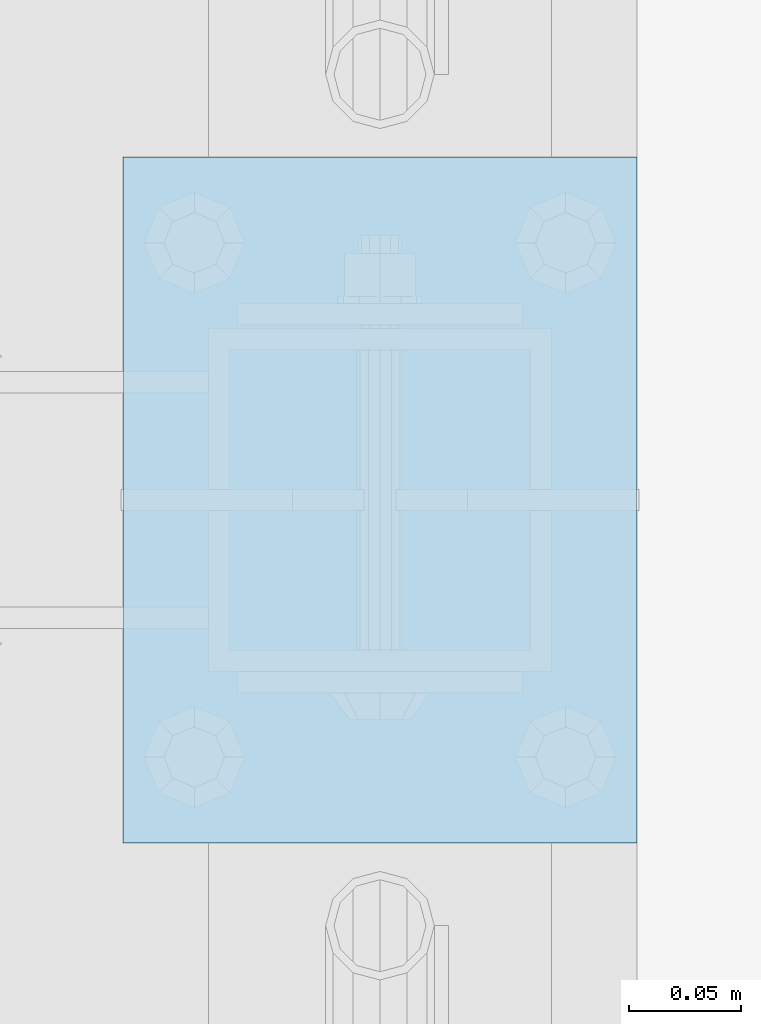
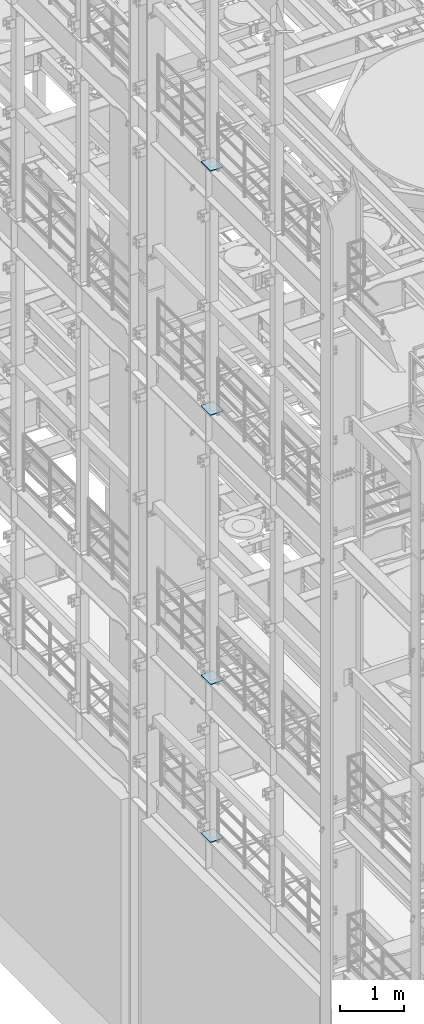
# One storey, part 1534 of 1876: 4 plates, 4 elements without a shape of their own.
"""IFC2X3 building model written with IfcOpenShell, lengths in millimetres."""

from ifc_helpers import new_model, si_unit, frame, origin_with_axes, place, context, subcontext, project, spatial, faceted_brep, material, type_object, element, aggregate, save


model = new_model("IFC2X3")

# Units and contexts
model_context = context("Model", 3, precision=1e-05, world=origin_with_axes())
body_context = subcontext(model_context, "Body", "Model", "MODEL_VIEW")
ifc_project = project(units=[si_unit("LENGTHUNIT", "METRE", prefix="MILLI"), si_unit("AREAUNIT", "SQUARE_METRE"), si_unit("VOLUMEUNIT", "CUBIC_METRE"), si_unit("MASSUNIT", "GRAM", prefix="KILO"), si_unit("TIMEUNIT", "SECOND"), si_unit("PLANEANGLEUNIT", "RADIAN"), si_unit("SOLIDANGLEUNIT", "STERADIAN"), si_unit("THERMODYNAMICTEMPERATUREUNIT", "DEGREE_CELSIUS"), si_unit("LUMINOUSINTENSITYUNIT", "LUMEN")], contexts=[model_context])

# Site, building, storey
site_placement = place(None, origin_with_axes())
site = spatial("IfcSite", under=ifc_project, at=site_placement, CompositionType="ELEMENT")
building_placement = place(site_placement, origin_with_axes())
building = spatial("IfcBuilding", under=site, at=building_placement, Name="Undefined", CompositionType="ELEMENT")
storey_placement = place(building_placement, origin_with_axes())
storey = spatial("IfcBuildingStorey", under=building, at=storey_placement, Name="Undefined", CompositionType="ELEMENT", Elevation=0.0)

# Assembly, plate
assembly_1_placement = place(storey_placement, origin_with_axes())
assembly_1 = element("IfcElementAssembly", 1, at=assembly_1_placement, inside=storey, Name="BEAM", AssemblyPlace="NOTDEFINED", PredefinedType="RIGID_FRAME")
ifc_material = material(Name="STEEL/A36")
plate_type = type_object("IfcPlateType", PredefinedType="NOTDEFINED")
plate_1_placement = place(assembly_1_placement, frame((-114.3, -660.400000000001, 17989.55), z_axis=(0.0, 1.0, 0.0), x_axis=(1.0, 0.0, 0.0)))
plate_1 = element("IfcPlate", 2, at=plate_1_placement, type_object=plate_type, material=ifc_material, Name="PLATE", context=body_context, shape_type="Brep", body=[
    faceted_brep([(0.0, -6.35000000000036, 0.0), (0.0, -6.35000000000036, 304.799987792969), (0.0, 6.35000000000036, 304.799987792969), (0.0, 6.35000000000036, 0.0), (228.600006103516, -6.34999999999854, 304.799987792969), (228.600006103516, 6.34999999999854, 304.799987792969), (228.600006103516, -6.34999999999854, 0.0), (228.600006103516, 6.34999999999854, 0.0)], [[[0, 1, 2, 3]], [[1, 4, 5, 2]], [[4, 6, 7, 5]], [[6, 0, 3, 7]], [[5, 7, 3, 2]], [[6, 4, 1, 0]]]),
])
aggregate(assembly_1, [plate_1])

assembly_2_placement = place(storey_placement, origin_with_axes())
assembly_2 = element("IfcElementAssembly", 3, at=assembly_2_placement, inside=storey, Name="BEAM", AssemblyPlace="NOTDEFINED", PredefinedType="RIGID_FRAME")
plate_2_placement = place(assembly_2_placement, frame((-114.3, -660.400000000001, 13315.95), z_axis=(0.0, 1.0, 0.0), x_axis=(1.0, 0.0, 0.0)))
plate_2 = element("IfcPlate", 4, at=plate_2_placement, type_object=plate_type, material=ifc_material, Name="PLATE", context=body_context, shape_type="Brep", body=[
    faceted_brep([(0.0, -6.35000000000036, 0.0), (0.0, -6.35000000000036, 304.799987792969), (0.0, 6.35000000000036, 304.799987792969), (0.0, 6.35000000000036, 0.0), (228.600006103516, -6.34999999999854, 304.799987792969), (228.600006103516, 6.34999999999854, 304.799987792969), (228.600006103516, -6.34999999999854, 0.0), (228.600006103516, 6.34999999999854, 0.0)], [[[0, 1, 2, 3]], [[1, 4, 5, 2]], [[4, 6, 7, 5]], [[6, 0, 3, 7]], [[5, 7, 3, 2]], [[6, 4, 1, 0]]]),
])
aggregate(assembly_2, [plate_2])

assembly_3_placement = place(storey_placement, origin_with_axes())
assembly_3 = element("IfcElementAssembly", 5, at=assembly_3_placement, inside=storey, Name="BEAM", AssemblyPlace="NOTDEFINED", PredefinedType="RIGID_FRAME")
plate_3_placement = place(assembly_3_placement, frame((-114.3, -660.400000000001, 8159.75), z_axis=(0.0, 1.0, 0.0), x_axis=(1.0, 0.0, 0.0)))
plate_3 = element("IfcPlate", 6, at=plate_3_placement, type_object=plate_type, material=ifc_material, Name="PLATE", context=body_context, shape_type="Brep", body=[
    faceted_brep([(0.0, -6.35000000000036, 0.0), (0.0, -6.35000000000036, 304.799987792969), (0.0, 6.35000000000036, 304.799987792969), (0.0, 6.35000000000036, 0.0), (228.600006103516, -6.34999999999854, 304.799987792969), (228.600006103516, 6.34999999999854, 304.799987792969), (228.600006103516, -6.34999999999854, 0.0), (228.600006103516, 6.34999999999854, 0.0)], [[[0, 1, 2, 3]], [[1, 4, 5, 2]], [[4, 6, 7, 5]], [[6, 0, 3, 7]], [[5, 7, 3, 2]], [[6, 4, 1, 0]]]),
])
aggregate(assembly_3, [plate_3])

assembly_4_placement = place(storey_placement, origin_with_axes())
assembly_4 = element("IfcElementAssembly", 7, at=assembly_4_placement, inside=storey, Name="BEAM", AssemblyPlace="NOTDEFINED", PredefinedType="RIGID_FRAME")
plate_4_placement = place(assembly_4_placement, frame((-114.3, -660.4, 5137.15), z_axis=(0.0, 1.0, 0.0), x_axis=(1.0, 0.0, 0.0)))
plate_4 = element("IfcPlate", 8, at=plate_4_placement, type_object=plate_type, material=ifc_material, Name="PLATE", context=body_context, shape_type="Brep", body=[
    faceted_brep([(0.0, -6.35000000000036, 0.0), (0.0, -6.35000000000036, 304.799987792969), (0.0, 6.35000000000036, 304.799987792969), (0.0, 6.35000000000036, 0.0), (228.600006103516, -6.34999999999854, 304.799987792969), (228.600006103516, 6.34999999999854, 304.799987792969), (228.600006103516, -6.34999999999854, 0.0), (228.600006103516, 6.34999999999854, 0.0)], [[[0, 1, 2, 3]], [[1, 4, 5, 2]], [[4, 6, 7, 5]], [[6, 0, 3, 7]], [[5, 7, 3, 2]], [[6, 4, 1, 0]]]),
])
aggregate(assembly_4, [plate_4])

save(model, "model.ifc")
